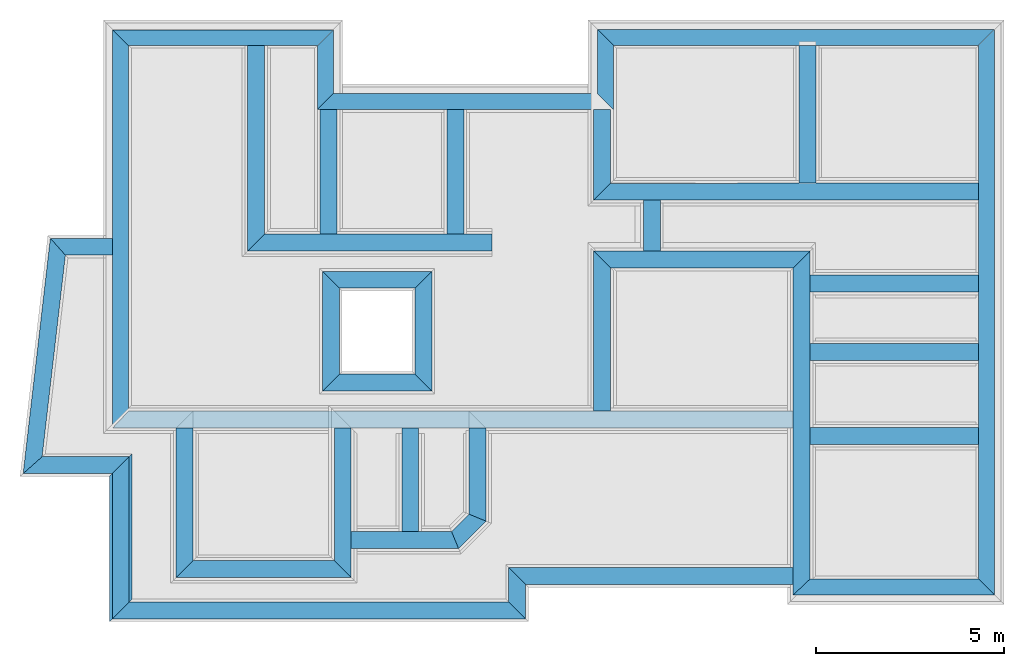
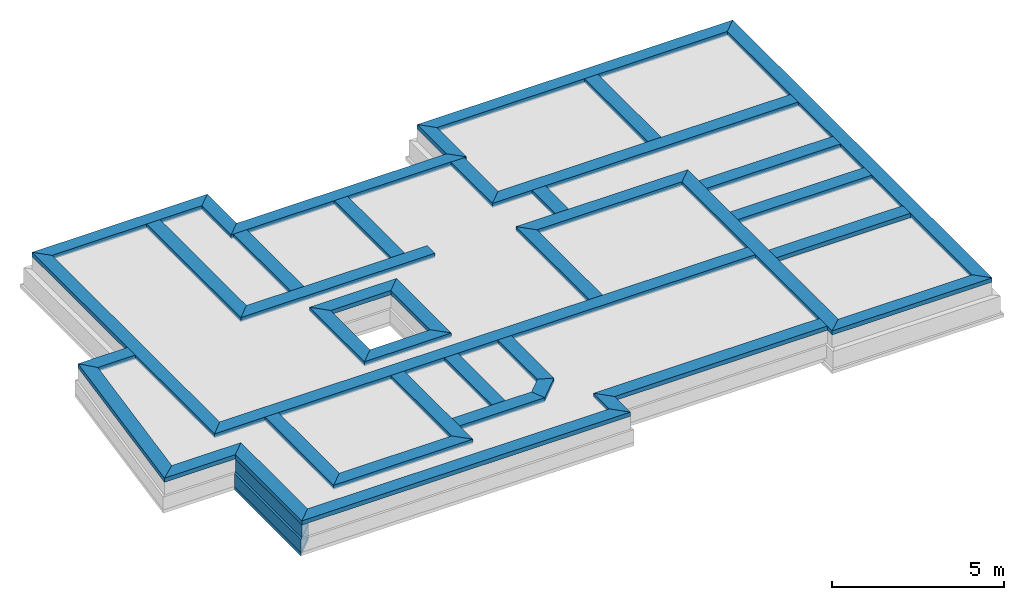
# One storey, part 1 of 6: 41 beams, 3 walls.
"""IFC4X3_ADD2 building model written with IfcOpenShell, lengths in metres."""

from ifc_helpers import new_model, entity, si_unit, converted_unit, frame, origin_with_axes, origin_2d_with_axis, place, context, subcontext, project, spatial, line, indexed_curve, outline, extrude, material, layer, layer_set, layer_usage, type_object, element, save


model = new_model("IFC4X3_ADD2")

# Units and contexts
model_context = context("Model", 3, precision=1e-05, world=origin_with_axes())
plan_context = context("Plan", 2, precision=1e-05, world=origin_2d_with_axis())
body_context = subcontext(model_context, "Body", "Model", "MODEL_VIEW")
ifc_project = project(units=[si_unit("VOLUMEUNIT", "CUBIC_METRE"), si_unit("LENGTHUNIT", "METRE"), converted_unit("PLANEANGLEUNIT", "degree", entity("IfcReal", 0.0174532925199433), si_unit("PLANEANGLEUNIT", "RADIAN"), dimensions=[0, 0, 0, 0, 0, 0, 0]), si_unit("AREAUNIT", "SQUARE_METRE")], contexts=[model_context, plan_context])

# Site, building, storey
site_placement = place(None, origin_with_axes())
site = spatial("IfcSite", under=ifc_project, at=site_placement)
building_placement = place(site_placement, origin_with_axes())
building = spatial("IfcBuilding", under=site, at=building_placement, Name="Building")
storey_placement = place(building_placement, frame((0.0, 0.0, -0.870000004768372), z_axis=(0.0, 0.0, 1.0), x_axis=(1.0, 0.0, 0.0)))
storey = spatial("IfcBuildingStorey", under=building, at=storey_placement, Name="Footing")

# Beams
ifc_material_1 = material(Name="brick2", Category="Materials")
ifc_layer_1 = layer(ifc_material_1, 0.00999999977648258)
ifc_material_2 = material(Name="Concrete")
ifc_layer_2 = layer(ifc_material_2, 0.405000001192093)
ifc_layer_3 = layer(ifc_material_1, 0.00999999977648258)
ifc_layer_set_1 = layer_set([ifc_layer_1, ifc_layer_2, ifc_layer_3], Name="concrete")
ifc_layer_usage_1 = layer_usage(ifc_layer_set_1, "AXIS2", "POSITIVE", 0.0)
beam_type_1 = type_object("IfcBeamType", Name="425mm wide beam", PredefinedType="BEAM", material=ifc_layer_set_1)
beam_1_placement = place(storey_placement, frame((18.1166839599609, 25.9979019165039, 1.16999995708466), z_axis=(0.0, 0.0, 1.0), x_axis=(3.13916473260163e-07, -0.999999999999951, 0.0)))
element("IfcBeam", 1, at=beam_1_placement, inside=storey, type_object=beam_type_1, material=ifc_layer_usage_1, Name="Beam", context=body_context, shape_type="SweptSolid", body=[
    extrude(outline(indexed_curve([(-0.425000000745059, 0.0), (-1.85773430742357e-08, 0.425000000745058), (1.70799196416283, 0.425000000745058), (1.28299198199511, 0.0)], segments=[line(1, 2, 3, 4, 1)])), origin_with_axes(), (0.0, 0.0, 1.0), 0.150000005960464),
])
ifc_layer_usage_2 = layer_usage(ifc_layer_set_1, "AXIS2", "POSITIVE", 0.0)
beam_2_placement = place(storey_placement, frame((10.6593037587962, 24.2899072712673, 1.16999995708466), z_axis=(0.0, 0.0, 1.0), x_axis=(0.999999999999936, 3.57627868652321e-07, 0.0)))
element("IfcBeam", 2, at=beam_2_placement, inside=storey, type_object=beam_type_1, material=ifc_layer_usage_2, Name="Beam", context=body_context, shape_type="SweptSolid", body=[
    extrude(outline(indexed_curve([(0.0, 0.0), (0.425000048504974, 0.425000000745058), (7.45738073603171, 0.425000000745058), (7.88238071161483, 0.0)], segments=[line(1, 2, 3, 4, 1)])), origin_with_axes(), (0.0, 0.0, 1.0), 0.150000005960464),
])
ifc_layer_usage_3 = layer_usage(ifc_layer_set_1, "AXIS2", "POSITIVE", 0.0)
beam_3_placement = place(storey_placement, frame((18.1166839599609, 25.9979019209745, 1.16999995708466), z_axis=(0.0, 0.0, 1.0), x_axis=(0.999999999999936, 3.57627868652321e-07, 0.0)))
element("IfcBeam", 3, at=beam_3_placement, inside=storey, type_object=beam_type_1, material=ifc_layer_usage_3, Name="Beam", context=body_context, shape_type="SweptSolid", body=[
    extrude(outline(indexed_curve([(0.425000000745059, 0.0), (2.51619385810791e-08, 0.425000000745058), (10.569989032995, 0.425000000745058), (10.1449890136726, 0.0)], segments=[line(1, 2, 3, 4, 1)])), origin_with_axes(), (0.0, 0.0, 1.0), 0.150000005960464),
])
ifc_layer_usage_4 = layer_usage(ifc_layer_set_1, "AXIS2", "POSITIVE", 0.0)
beam_4_placement = place(storey_placement, frame((28.2616729736329, 25.9979055491053, 1.16999995708466), z_axis=(0.0, 0.0, 1.0), x_axis=(3.13916473260163e-07, -0.999999999999951, 0.0)))
element("IfcBeam", 4, at=beam_4_placement, inside=storey, type_object=beam_type_1, material=ifc_layer_usage_4, Name="Beam", context=body_context, shape_type="SweptSolid", body=[
    extrude(outline(indexed_curve([(0.0, 0.0), (-0.425000019322402, 0.425000000745058), (14.6285606951178, 0.425000000745058), (14.2035607129501, 0.0)], segments=[line(1, 2, 3, 4, 1)])), origin_with_axes(), (0.0, 0.0, 1.0), 0.150000005960464),
])
ifc_layer_usage_5 = layer_usage(ifc_layer_set_1, "AXIS2", "POSITIVE", 0.0)
beam_5_placement = place(storey_placement, frame((23.3250172254903, 11.3693430699236, 1.16999995708466), z_axis=(0.0, 0.0, 1.0), x_axis=(0.999999999999936, 3.57627868652321e-07, 0.0)))
element("IfcBeam", 5, at=beam_5_placement, inside=storey, type_object=beam_type_1, material=ifc_layer_usage_5, Name="Beam", context=body_context, shape_type="SweptSolid", body=[
    extrude(outline(indexed_curve([(0.0, 0.0), (0.450000020620197, 0.425000000745058), (4.93666035886637, 0.425000000745058), (5.36166034103409, 0.0)], segments=[line(1, 2, 3, 4, 1)])), origin_with_axes(), (0.0, 0.0, 1.0), 0.150000005960464),
])
ifc_layer_usage_6 = layer_usage(ifc_layer_set_1, "AXIS2", "POSITIVE", 0.0)
beam_6_placement = place(storey_placement, frame((5.21403593350073, 25.9879012442737, 1.16999995708466), z_axis=(0.0, 0.0, 1.0), x_axis=(3.13916473260163e-07, -0.999999999999951, 0.0)))
element("IfcBeam", 6, at=beam_6_placement, inside=storey, type_object=beam_type_1, material=ifc_layer_usage_6, Name="Beam", context=body_context, shape_type="SweptSolid", body=[
    extrude(outline(indexed_curve([(-0.425000000745059, 0.0), (-1.85773430742357e-08, 0.425000000745058), (9.7218833779098, 0.425000000745058), (10.1718834035535, 0.0)], segments=[line(1, 2, 3, 4, 1)])), origin_with_axes(), (0.0, 0.0, 1.0), 0.150000005960464),
])
ifc_layer_usage_7 = layer_usage(ifc_layer_set_1, "AXIS2", "POSITIVE", 0.0)
beam_7_placement = place(storey_placement, frame((5.21403593350073, 25.9879012442737, 1.16999995708466), z_axis=(0.0, 0.0, 1.0), x_axis=(0.999999999999936, 3.57627868652321e-07, 0.0)))
element("IfcBeam", 7, at=beam_7_placement, inside=storey, type_object=beam_type_1, material=ifc_layer_usage_7, Name="Beam", context=body_context, shape_type="SweptSolid", body=[
    extrude(outline(indexed_curve([(0.425000000745059, 0.0), (1.96829825992962e-08, 0.425000000745058), (5.87026742918612, 0.425000000745058), (5.44526740885958, 0.0)], segments=[line(1, 2, 3, 4, 1)])), origin_with_axes(), (0.0, 0.0, 1.0), 0.150000005960464),
])
ifc_layer_usage_8 = layer_usage(ifc_layer_set_1, "AXIS2", "POSITIVE", 0.0)
beam_8_placement = place(storey_placement, frame((10.65930334236, 25.9879031916531, 1.16999995708466), z_axis=(0.0, 0.0, 1.0), x_axis=(3.13916473260163e-07, -0.999999999999951, 0.0)))
element("IfcBeam", 8, at=beam_8_placement, inside=storey, type_object=beam_type_1, material=ifc_layer_usage_8, Name="Beam", context=body_context, shape_type="SweptSolid", body=[
    extrude(outline(indexed_curve([(0.0, 0.0), (-0.425000019322402, 0.425000000745058), (1.2729959010635, 0.425000000745058), (1.6979959203859, 0.0)], segments=[line(1, 2, 3, 4, 1)])), origin_with_axes(), (0.0, 0.0, 1.0), 0.150000005960464),
])
ifc_layer_4 = layer(ifc_material_1, 0.00999999977648258)
ifc_material_3 = material(Name="Stone", Category="Structure")
ifc_layer_5 = layer(ifc_material_3, 0.430000007152557)
ifc_layer_6 = layer(ifc_material_1, 0.00999999977648258)
ifc_layer_set_2 = layer_set([ifc_layer_4, ifc_layer_5, ifc_layer_6], Name="concrete")
ifc_layer_usage_9 = layer_usage(ifc_layer_set_2, "AXIS2", "POSITIVE", 0.0)
beam_type_2 = type_object("IfcBeamType", Name="450mm wide beam", PredefinedType="BEAM", material=ifc_layer_set_2)
beam_9_placement = place(storey_placement, frame((8.80813704222451, 25.9978993535042, 1.16999995708466), z_axis=(0.0, 0.0, 1.0), x_axis=(1.94707183709394e-07, -0.999999999999981, 0.0)))
element("IfcBeam", 9, at=beam_9_placement, inside=storey, type_object=beam_type_2, material=ifc_layer_usage_9, Name="Beam", context=body_context, shape_type="SweptSolid", body=[
    extrude(outline(indexed_curve([(0.0, 0.0), (0.0, 0.450000006705522), (5.02351283316316, 0.450000006705522), (5.47351248493011, 0.0)], segments=[line(1, 2, 3, 4, 1)])), origin_with_axes(), (0.0, 0.0, 1.0), 0.150000005960464),
])
ifc_layer_usage_10 = layer_usage(ifc_layer_set_2, "AXIS2", "POSITIVE", 0.0)
beam_10_placement = place(storey_placement, frame((14.110216841721, 24.2899085054099, 1.16999995708466), z_axis=(0.0, 0.0, 1.0), x_axis=(3.13916473260163e-07, -0.999999999999951, 0.0)))
element("IfcBeam", 10, at=beam_10_placement, inside=storey, type_object=beam_type_2, material=ifc_layer_usage_10, Name="Beam", context=body_context, shape_type="SweptSolid", body=[
    extrude(outline(indexed_curve([(0.0, 0.0), (-1.96701282195799e-08, 0.450000006705522), (3.31552518321818, 0.450000006705522), (3.31552477503988, 0.0)], segments=[line(1, 2, 3, 4, 1)])), origin_with_axes(), (0.0, 0.0, 1.0), 0.150000005960464),
])
ifc_layer_usage_11 = layer_usage(ifc_layer_set_2, "AXIS2", "POSITIVE", 0.0)
beam_11_placement = place(storey_placement, frame((23.4816800811879, 25.9979038396466, 1.16999995708466), z_axis=(0.0, 0.0, 1.0), x_axis=(3.13916473260163e-07, -0.999999999999951, 0.0)))
element("IfcBeam", 11, at=beam_11_placement, inside=storey, type_object=beam_type_2, material=ifc_layer_usage_11, Name="Beam", context=body_context, shape_type="SweptSolid", body=[
    extrude(outline(indexed_curve([(0.0, 0.0), (-1.96701282195799e-08, 0.450000006705522), (3.67000913781649, 0.450000006705522), (3.67000915865293, 0.0)], segments=[line(1, 2, 3, 4, 1)])), origin_with_axes(), (0.0, 0.0, 1.0), 0.150000005960464),
])
ifc_layer_usage_12 = layer_usage(ifc_layer_set_2, "AXIS2", "POSITIVE", 0.0)
beam_12_placement = place(storey_placement, frame((18.0166816711424, 24.2899099024706, 1.16999995708466), z_axis=(0.0, 0.0, 1.0), x_axis=(3.13916473260163e-07, -0.999999999999951, 0.0)))
element("IfcBeam", 12, at=beam_12_placement, inside=storey, type_object=beam_type_2, material=ifc_layer_usage_12, Name="Beam", context=body_context, shape_type="SweptSolid", body=[
    extrude(outline(indexed_curve([(0.0, 0.0), (-1.96701282195798e-08, 0.450000006705522), (1.96201718267913, 0.450000006705522), (2.41201721245263, 0.0)], segments=[line(1, 2, 3, 4, 1)])), origin_with_axes(), (0.0, 0.0, 1.0), 0.150000005960464),
])
ifc_layer_usage_13 = layer_usage(ifc_layer_set_2, "AXIS2", "POSITIVE", 0.0)
beam_13_placement = place(storey_placement, frame((18.0166824547765, 21.8778927056883, 1.16999995708466), z_axis=(0.0, 0.0, 1.0), x_axis=(0.999999999999936, 3.57627868652321e-07, 0.0)))
element("IfcBeam", 13, at=beam_13_placement, inside=storey, type_object=beam_type_2, material=ifc_layer_usage_13, Name="Beam", context=body_context, shape_type="SweptSolid", body=[
    extrude(outline(indexed_curve([(0.0, 0.0), (0.450000021438708, 0.450000006705522), (10.2449918318659, 0.450000006705522), (10.2449918121957, 0.0)], segments=[line(1, 2, 3, 4, 1)])), origin_with_axes(), (0.0, 0.0, 1.0), 0.150000005960464),
])
ifc_layer_usage_14 = layer_usage(ifc_layer_set_2, "AXIS2", "POSITIVE", 0.0)
beam_14_placement = place(storey_placement, frame((23.3250144526521, 20.0728968029, 1.16999995708466), z_axis=(0.0, 0.0, 1.0), x_axis=(3.13916473260163e-07, -0.999999999999951, 0.0)))
element("IfcBeam", 14, at=beam_14_placement, inside=storey, type_object=beam_type_2, material=ifc_layer_usage_14, Name="Beam", context=body_context, shape_type="SweptSolid", body=[
    extrude(outline(indexed_curve([(0.0, 0.0), (-0.450000027679134, 0.450000006705522), (8.2785537125617, 0.450000006705522), (8.70355373297689, 0.0)], segments=[line(1, 2, 3, 4, 1)])), origin_with_axes(), (0.0, 0.0, 1.0), 0.150000005960464),
])
ifc_layer_usage_15 = layer_usage(ifc_layer_set_2, "AXIS2", "POSITIVE", 0.0)
beam_15_placement = place(storey_placement, frame((18.0166815696099, 20.072894889116, 1.16999995708466), z_axis=(0.0, 0.0, 1.0), x_axis=(0.999999999999936, 3.57627868652321e-07, 0.0)))
element("IfcBeam", 15, at=beam_15_placement, inside=storey, type_object=beam_type_2, material=ifc_layer_usage_15, Name="Beam", context=body_context, shape_type="SweptSolid", body=[
    extrude(outline(indexed_curve([(0.450000006705523, 0.0), (1.96701282484391e-08, 0.450000006705522), (5.75833290805005, 0.450000006705522), (5.30833288304257, 0.0)], segments=[line(1, 2, 3, 4, 1)])), origin_with_axes(), (0.0, 0.0, 1.0), 0.150000005960464),
])
ifc_layer_usage_16 = layer_usage(ifc_layer_set_2, "AXIS2", "POSITIVE", 0.0)
beam_16_placement = place(storey_placement, frame((23.3250146565525, 19.4295903581414, 1.16999995708466), z_axis=(0.0, 0.0, 1.0), x_axis=(0.999999999999936, 3.57627868652321e-07, 0.0)))
element("IfcBeam", 16, at=beam_16_placement, inside=storey, type_object=beam_type_2, material=ifc_layer_usage_16, Name="Beam", context=body_context, shape_type="SweptSolid", body=[
    extrude(outline(indexed_curve([(0.450000006705522, 0.0), (0.450000025007475, 0.450000006705522), (4.93666039865257, 0.450000006705522), (4.93666037898244, 0.0)], segments=[line(1, 2, 3, 4, 1)])), origin_with_axes(), (0.0, 0.0, 1.0), 0.150000005960464),
])
ifc_layer_usage_17 = layer_usage(ifc_layer_set_2, "AXIS2", "POSITIVE", 0.0)
beam_17_placement = place(storey_placement, frame((23.3250141143799, 17.6093635559082, 1.16999995708466), z_axis=(0.0, 0.0, 1.0), x_axis=(0.999999999999936, 3.57627868652321e-07, 0.0)))
element("IfcBeam", 17, at=beam_17_placement, inside=storey, type_object=beam_type_2, material=ifc_layer_usage_17, Name="Beam", context=body_context, shape_type="SweptSolid", body=[
    extrude(outline(indexed_curve([(0.450000006705522, 0.0), (0.450000025007475, 0.450000006705522), (4.93666039865257, 0.450000006705522), (4.93666037898244, 0.0)], segments=[line(1, 2, 3, 4, 1)])), origin_with_axes(), (0.0, 0.0, 1.0), 0.150000005960464),
])
ifc_layer_usage_18 = layer_usage(ifc_layer_set_2, "AXIS2", "POSITIVE", 0.0)
beam_18_placement = place(storey_placement, frame((23.3250141143799, 15.3793487548828, 1.16999995708466), z_axis=(0.0, 0.0, 1.0), x_axis=(0.999999999999936, 3.57627868652321e-07, 0.0)))
element("IfcBeam", 18, at=beam_18_placement, inside=storey, type_object=beam_type_2, material=ifc_layer_usage_18, Name="Beam", context=body_context, shape_type="SweptSolid", body=[
    extrude(outline(indexed_curve([(0.450000006705522, 0.0), (0.450000025007475, 0.450000006705522), (4.93666039865257, 0.450000006705522), (4.93666037898244, 0.0)], segments=[line(1, 2, 3, 4, 1)])), origin_with_axes(), (0.0, 0.0, 1.0), 0.150000005960464),
])
ifc_layer_usage_19 = layer_usage(ifc_layer_set_2, "AXIS2", "POSITIVE", 0.0)
beam_19_placement = place(storey_placement, frame((19.3416843414307, 21.877893447876, 1.16999995708466), z_axis=(0.0, 0.0, 1.0), x_axis=(3.13916473260163e-07, -0.999999999999951, 0.0)))
element("IfcBeam", 19, at=beam_19_placement, inside=storey, type_object=beam_type_2, material=ifc_layer_usage_19, Name="Beam", context=body_context, shape_type="SweptSolid", body=[
    extrude(outline(indexed_curve([(0.0, 0.0), (-2.08324514101375e-08, 0.450000006705522), (1.35499778938149, 0.450000006705522), (1.35499781047584, 0.0)], segments=[line(1, 2, 3, 4, 1)])), origin_with_axes(), (0.0, 0.0, 1.0), 0.150000005960464),
])
ifc_layer_usage_20 = layer_usage(ifc_layer_set_2, "AXIS2", "POSITIVE", 0.0)
beam_20_placement = place(storey_placement, frame((18.0166815696099, 20.0728948876918, 1.16999995708466), z_axis=(0.0, 0.0, 1.0), x_axis=(3.13916473260163e-07, -0.999999999999951, 0.0)))
element("IfcBeam", 20, at=beam_20_placement, inside=storey, type_object=beam_type_2, material=ifc_layer_usage_20, Name="Beam", context=body_context, shape_type="SweptSolid", body=[
    extrude(outline(indexed_curve([(-0.450000006705523, 0.0), (-2.09736109838054e-08, 0.450000006705522), (3.80687243920009, 0.450000006705522), (3.80687245990194, 0.0)], segments=[line(1, 2, 3, 4, 1)])), origin_with_axes(), (0.0, 0.0, 1.0), 0.150000005960464),
])
ifc_layer_usage_21 = layer_usage(ifc_layer_set_2, "AXIS2", "POSITIVE", 0.0)
beam_21_placement = place(storey_placement, frame((5.21403910016029, 15.8160178407207, 1.16999995708466), z_axis=(0.0, 0.0, 1.0), x_axis=(0.999999999999936, 3.57627868652321e-07, 0.0)))
element("IfcBeam", 21, at=beam_21_placement, inside=storey, type_object=beam_type_2, material=ifc_layer_usage_21, Name="Beam", context=body_context, shape_type="SweptSolid", body=[
    extrude(outline(indexed_curve([(0.0, 0.0), (0.425000021585864, 0.450000006705522), (18.1109767200399, 0.450000006705522), (18.1109767017379, 0.0)], segments=[line(1, 2, 3, 4, 1)])), origin_with_axes(), (0.0, 0.0, 1.0), 0.150000005960464),
])
ifc_layer_usage_22 = layer_usage(ifc_layer_set_2, "AXIS2", "POSITIVE", 0.0)
beam_22_placement = place(storey_placement, frame((14.6966757752904, 15.8160212390453, 1.16999995708466), z_axis=(0.0, 0.0, 1.0), x_axis=(3.13916473260163e-07, -0.999999999999951, 0.0)))
element("IfcBeam", 22, at=beam_22_placement, inside=storey, type_object=beam_type_2, material=ifc_layer_usage_22, Name="Beam", context=body_context, shape_type="SweptSolid", body=[
    extrude(outline(indexed_curve([(0.0, 0.0), (-2.0103359660383e-08, 0.450000006705522), (2.48110810332906, 0.450000006705522), (2.29471198139448, 0.0)], segments=[line(1, 2, 3, 4, 1)])), origin_with_axes(), (0.0, 0.0, 1.0), 0.150000005960464),
])
ifc_layer_usage_23 = layer_usage(ifc_layer_set_2, "AXIS2", "POSITIVE", 0.0)
beam_23_placement = place(storey_placement, frame((14.6966764956383, 13.5213092576509, 1.16999995708466), z_axis=(0.0, 0.0, 1.0), x_axis=(-0.707106602372588, -0.707106960000462, 0.0)))
element("IfcBeam", 23, at=beam_23_placement, inside=storey, type_object=beam_type_2, material=ifc_layer_usage_23, Name="Beam", context=body_context, shape_type="SweptSolid", body=[
    extrude(outline(indexed_curve([(0.0, 0.0), (-0.186396121934575, 0.450000006705522), (0.842713639025092, 0.450000006705522), (0.65631756226547, 0.0)], segments=[line(1, 2, 3, 4, 1)])), origin_with_axes(), (0.0, 0.0, 1.0), 0.150000005960464),
])
ifc_layer_usage_24 = layer_usage(ifc_layer_set_2, "AXIS2", "POSITIVE", 0.0)
beam_24_placement = place(storey_placement, frame((11.1129999696974, 12.6072214047061, 1.16999995708466), z_axis=(0.0, 0.0, 1.0), x_axis=(0.999999999999936, 3.57627868652321e-07, 0.0)))
element("IfcBeam", 24, at=beam_24_placement, inside=storey, type_object=beam_type_2, material=ifc_layer_usage_24, Name="Beam", context=body_context, shape_type="SweptSolid", body=[
    extrude(outline(indexed_curve([(0.450000006705523, 0.0), (0.450000026375651, 0.450000006705522), (3.11959019100417, 0.450000006705522), (3.30598626923792, 0.0)], segments=[line(1, 2, 3, 4, 1)])), origin_with_axes(), (0.0, 0.0, 1.0), 0.150000005960464),
])
ifc_layer_usage_25 = layer_usage(ifc_layer_set_2, "AXIS2", "POSITIVE", 0.0)
beam_25_placement = place(storey_placement, frame((12.9089555740357, 15.8160205991703, 1.16999995708466), z_axis=(0.0, 0.0, 1.0), x_axis=(3.13916473260163e-07, -0.999999999999951, 0.0)))
element("IfcBeam", 25, at=beam_25_placement, inside=storey, type_object=beam_type_2, material=ifc_layer_usage_25, Name="Beam", context=body_context, shape_type="SweptSolid", body=[
    extrude(outline(indexed_curve([(0.0, 0.0), (-2.00521794216641e-08, 0.450000006705522), (2.75879851585852, 0.450000006705522), (2.75879853752143, 0.0)], segments=[line(1, 2, 3, 4, 1)])), origin_with_axes(), (0.0, 0.0, 1.0), 0.150000005960464),
])
ifc_layer_usage_26 = layer_usage(ifc_layer_set_2, "AXIS2", "POSITIVE", 0.0)
beam_26_placement = place(storey_placement, frame((11.1129989624023, 15.8160209655762, 1.16999995708466), z_axis=(0.0, 0.0, 1.0), x_axis=(3.13916473260163e-07, -0.999999999999951, 0.0)))
element("IfcBeam", 26, at=beam_26_placement, inside=storey, type_object=beam_type_2, material=ifc_layer_usage_26, Name="Beam", context=body_context, shape_type="SweptSolid", body=[
    extrude(outline(indexed_curve([(0.0, 0.0), (0.0, 0.450000006705522), (3.9799980040806, 0.450000006705522), (3.52999801830902, 0.0)], segments=[line(1, 2, 3, 4, 1)])), origin_with_axes(), (0.0, 0.0, 1.0), 0.150000005960464),
])
ifc_layer_usage_27 = layer_usage(ifc_layer_set_2, "AXIS2", "POSITIVE", 0.0)
beam_27_placement = place(storey_placement, frame((6.9035966969277, 11.8360214233398, 1.16999995708466), z_axis=(0.0, 0.0, 1.0), x_axis=(0.999999999999936, 3.57627868652321e-07, 0.0)))
element("IfcBeam", 27, at=beam_27_placement, inside=storey, type_object=beam_type_2, material=ifc_layer_usage_27, Name="Beam", context=body_context, shape_type="SweptSolid", body=[
    extrude(outline(indexed_curve([(0.0, 0.0), (0.450000026375651, 0.450000006705522), (4.20940353453194, 0.450000006705522), (4.65940352156734, 0.0)], segments=[line(1, 2, 3, 4, 1)])), origin_with_axes(), (0.0, 0.0, 1.0), 0.150000005960464),
])
ifc_layer_usage_28 = layer_usage(ifc_layer_set_2, "AXIS2", "POSITIVE", 0.0)
beam_28_placement = place(storey_placement, frame((6.90359544754028, 15.8160209655762, 1.16999995708466), z_axis=(0.0, 0.0, 1.0), x_axis=(3.13916473260163e-07, -0.999999999999951, 0.0)))
element("IfcBeam", 28, at=beam_28_placement, inside=storey, type_object=beam_type_2, material=ifc_layer_usage_28, Name="Beam", context=body_context, shape_type="SweptSolid", body=[
    extrude(outline(indexed_curve([(0.0, 0.0), (0.0, 0.450000006705522), (3.52999951459715, 0.450000006705522), (3.97999954223662, 0.0)], segments=[line(1, 2, 3, 4, 1)])), origin_with_axes(), (0.0, 0.0, 1.0), 0.150000005960464),
])
ifc_layer_usage_29 = layer_usage(ifc_layer_set_2, "AXIS2", "POSITIVE", 0.0)
beam_29_placement = place(storey_placement, frame((10.734302408552, 24.2899072980889, 1.16999995708466), z_axis=(0.0, 0.0, 1.0), x_axis=(3.13916473260163e-07, -0.999999999999951, 0.0)))
element("IfcBeam", 29, at=beam_29_placement, inside=storey, type_object=beam_type_2, material=ifc_layer_usage_29, Name="Beam", context=body_context, shape_type="SweptSolid", body=[
    extrude(outline(indexed_curve([(0.0, 0.0), (-1.96701281929279e-08, 0.450000006705522), (3.31552197348559, 0.450000006705522), (3.31552156530729, 0.0)], segments=[line(1, 2, 3, 4, 1)])), origin_with_axes(), (0.0, 0.0, 1.0), 0.150000005960464),
])
ifc_layer_usage_30 = layer_usage(ifc_layer_set_2, "AXIS2", "POSITIVE", 0.0)
beam_30_placement = place(storey_placement, frame((8.80813810795671, 20.5243868685742, 1.16999995708466), z_axis=(0.0, 0.0, 1.0), x_axis=(0.999999999999822, -5.960464477538e-07, 0.0)))
element("IfcBeam", 30, at=beam_30_placement, inside=storey, type_object=beam_type_2, material=ifc_layer_usage_30, Name="Beam", context=body_context, shape_type="SweptSolid", body=[
    extrude(outline(indexed_curve([(0.0, 0.0), (0.449999650866523, 0.450000006705522), (6.50208187103272, 0.450000006705522), (6.50208187103272, 0.0)], segments=[line(1, 2, 3, 4, 1)])), origin_with_axes(), (0.0, 0.0, 1.0), 0.150000005960464),
])
ifc_layer_usage_31 = layer_usage(ifc_layer_set_2, "AXIS2", "POSITIVE", 0.0)
beam_31_placement = place(storey_placement, frame((15.7540448127226, 11.6493429189982, 1.16999995708466), z_axis=(0.0, 0.0, 1.0), x_axis=(0.999999999999936, 3.57627868652321e-07, 0.0)))
element("IfcBeam", 31, at=beam_31_placement, inside=storey, type_object=beam_type_2, material=ifc_layer_usage_31, Name="Beam", context=body_context, shape_type="SweptSolid", body=[
    extrude(outline(indexed_curve([(0.450000006705523, 0.0), (1.96701282195799e-08, 0.450000006705522), (7.57097232813434, 0.450000006705522), (7.57097230983239, 0.0)], segments=[line(1, 2, 3, 4, 1)])), origin_with_axes(), (0.0, 0.0, 1.0), 0.150000005960464),
])
ifc_layer_usage_32 = layer_usage(ifc_layer_set_2, "AXIS2", "POSITIVE", 0.0)
beam_32_placement = place(storey_placement, frame((15.7540448127226, 11.6493429189982, 1.16999995708466), z_axis=(0.0, 0.0, 1.0), x_axis=(3.13916473260163e-07, -0.999999999999951, 0.0)))
element("IfcBeam", 32, at=beam_32_placement, inside=storey, type_object=beam_type_2, material=ifc_layer_usage_32, Name="Beam", context=body_context, shape_type="SweptSolid", body=[
    extrude(outline(indexed_curve([(-0.450000006705523, 0.0), (-2.04372883874935e-08, 0.450000006705522), (0.913205436559926, 0.450000006705522), (0.463205450491675, 0.0)], segments=[line(1, 2, 3, 4, 1)])), origin_with_axes(), (0.0, 0.0, 1.0), 0.150000005960464),
])
ifc_layer_usage_33 = layer_usage(ifc_layer_set_2, "AXIS2", "POSITIVE", 0.0)
beam_33_placement = place(storey_placement, frame((5.20271757983026, 10.7361336765302, 1.16999995708466), z_axis=(0.0, 0.0, 1.0), x_axis=(0.999999999999936, 3.57627868652321e-07, 0.0)))
element("IfcBeam", 33, at=beam_33_placement, inside=storey, type_object=beam_type_2, material=ifc_layer_usage_33, Name="Beam", context=body_context, shape_type="SweptSolid", body=[
    extrude(outline(indexed_curve([(0.0, 0.0), (0.45000002637565, 0.450000006705522), (10.5513275392333, 0.450000006705522), (11.0013275262687, 0.0)], segments=[line(1, 2, 3, 4, 1)])), origin_with_axes(), (0.0, 0.0, 1.0), 0.150000005960464),
])
ifc_layer_usage_34 = layer_usage(ifc_layer_set_2, "AXIS2", "POSITIVE", 0.0)
beam_34_placement = place(storey_placement, frame((5.20271636677999, 14.6003790231918, 1.16999995708466), z_axis=(0.0, 0.0, 1.0), x_axis=(3.13916473260163e-07, -0.999999999999951, 0.0)))
element("IfcBeam", 34, at=beam_34_placement, inside=storey, type_object=beam_type_2, material=ifc_layer_usage_34, Name="Beam", context=body_context, shape_type="SweptSolid", body=[
    extrude(outline(indexed_curve([(0.0, 0.0), (-0.450000028368439, 0.450000006705522), (3.41424531978198, 0.450000006705522), (3.86424534666183, 0.0)], segments=[line(1, 2, 3, 4, 1)])), origin_with_axes(), (0.0, 0.0, 1.0), 0.150000005960464),
])
ifc_layer_usage_35 = layer_usage(ifc_layer_set_2, "AXIS2", "POSITIVE", 0.0)
beam_35_placement = place(storey_placement, frame((3.28399853057781, 14.6003783249363, 1.16999995708466), z_axis=(0.0, 0.0, 1.0), x_axis=(0.999999999999936, 3.57627868652321e-07, 0.0)))
element("IfcBeam", 35, at=beam_35_placement, inside=storey, type_object=beam_type_2, material=ifc_layer_usage_35, Name="Beam", context=body_context, shape_type="SweptSolid", body=[
    extrude(outline(indexed_curve([(-0.452991198784577, 0.0), (0.0519713396144295, 0.450000006705522), (2.36871786257795, 0.450000006705522), (1.9187178362023, 0.0)], segments=[line(1, 2, 3, 4, 1)])), origin_with_axes(), (0.0, 0.0, 1.0), 0.150000005960464),
])
ifc_layer_usage_36 = layer_usage(ifc_layer_set_2, "AXIS2", "POSITIVE", 0.0)
beam_36_placement = place(storey_placement, frame((3.95536313564383, 20.4134866076835, 1.16999995708466), z_axis=(0.0, 0.0, 1.0), x_axis=(0.999999999999936, 3.57627868652321e-07, 0.0)))
element("IfcBeam", 36, at=beam_36_placement, inside=storey, type_object=beam_type_2, material=ifc_layer_usage_36, Name="Beam", context=body_context, shape_type="SweptSolid", body=[
    extrude(outline(indexed_curve([(0.0, 0.0), (-0.401019859170148, 0.450000006705522), (1.25867455409636, 0.450000006705522), (1.25867453325556, 0.0)], segments=[line(1, 2, 3, 4, 1)])), origin_with_axes(), (0.0, 0.0, 1.0), 0.150000005960464),
])
ifc_layer_usage_37 = layer_usage(ifc_layer_set_2, "AXIS2", "POSITIVE", 0.0)
beam_37_placement = place(storey_placement, frame((10.7956827422968, 19.5343851122715, 1.16999995708466), z_axis=(0.0, 0.0, 1.0), x_axis=(3.13916473260163e-07, -0.999999999999951, 0.0)))
element("IfcBeam", 37, at=beam_37_placement, inside=storey, type_object=beam_type_2, material=ifc_layer_usage_37, Name="Beam", context=body_context, shape_type="SweptSolid", body=[
    extrude(outline(indexed_curve([(-0.450000006705523, 0.0), (-1.96701281929279e-08, 0.450000006705522), (2.28836896166128, 0.450000006705522), (2.73836898803694, 0.0)], segments=[line(1, 2, 3, 4, 1)])), origin_with_axes(), (0.0, 0.0, 1.0), 0.150000005960464),
])
ifc_layer_usage_38 = layer_usage(ifc_layer_set_2, "AXIS2", "POSITIVE", 0.0)
beam_38_placement = place(storey_placement, frame((13.2589586517204, 19.5343859932076, 1.16999995708466), z_axis=(0.0, 0.0, 1.0), x_axis=(3.13916473260163e-07, -0.999999999999951, 0.0)))
element("IfcBeam", 38, at=beam_38_placement, inside=storey, type_object=beam_type_2, material=ifc_layer_usage_38, Name="Beam", context=body_context, shape_type="SweptSolid", body=[
    extrude(outline(indexed_curve([(0.0, 0.0), (-0.450000026375651, 0.450000006705522), (2.73836896836681, 0.450000006705522), (2.28836898133141, 0.0)], segments=[line(1, 2, 3, 4, 1)])), origin_with_axes(), (0.0, 0.0, 1.0), 0.150000005960464),
])
ifc_layer_usage_39 = layer_usage(ifc_layer_set_2, "AXIS2", "POSITIVE", 0.0)
beam_39_placement = place(storey_placement, frame((10.7956827422968, 19.5343851122715, 1.16999989748001), z_axis=(0.0, 0.0, 1.0), x_axis=(0.999999999999936, 3.57627868652321e-07, 0.0)))
element("IfcBeam", 39, at=beam_39_placement, inside=storey, type_object=beam_type_2, material=ifc_layer_usage_39, Name="Beam", context=body_context, shape_type="SweptSolid", body=[
    extrude(outline(indexed_curve([(0.450000006705523, 0.0), (1.96701282195799e-08, 0.450000006705522), (2.91327593579936, 0.450000006705522), (2.46327590942371, 0.0)], segments=[line(1, 2, 3, 4, 1)])), origin_with_axes(), (0.0, 0.0, 1.0), 0.150000005960464),
])
ifc_layer_usage_40 = layer_usage(ifc_layer_set_2, "AXIS2", "POSITIVE", 0.0)
beam_40_placement = place(storey_placement, frame((10.795683601916, 16.7960161242347, 1.16999989748001), z_axis=(0.0, 0.0, 1.0), x_axis=(0.999999999999936, 3.57627868652321e-07, 0.0)))
element("IfcBeam", 40, at=beam_40_placement, inside=storey, type_object=beam_type_2, material=ifc_layer_usage_40, Name="Beam", context=body_context, shape_type="SweptSolid", body=[
    extrude(outline(indexed_curve([(0.0, 0.0), (0.450000026375651, 0.450000006705522), (2.46327592909384, 0.450000006705522), (2.91327591612923, 0.0)], segments=[line(1, 2, 3, 4, 1)])), origin_with_axes(), (0.0, 0.0, 1.0), 0.150000005960464),
])
ifc_layer_usage_41 = layer_usage(ifc_layer_set_2, "AXIS2", "POSITIVE", 0.0)
beam_41_placement = place(storey_placement, frame((3.28399853098188, 14.600378328435, 1.16999995708466), z_axis=(0.0, 0.0, 1.0), x_axis=(0.114728892793783, 0.99339683971629, 0.0)))
element("IfcBeam", 41, at=beam_41_placement, inside=storey, type_object=beam_type_2, material=ifc_layer_usage_41, Name="Beam", context=body_context, shape_type="SweptSolid", body=[
    extrude(outline(indexed_curve([(0.452991199106924, 0.0), (-0.0519713424240595, 0.450000006705522), (6.25276817398, 0.450000006705522), (5.85174831480985, 0.0)], segments=[line(1, 2, 3, 4, 1)])), origin_with_axes(), (0.0, 0.0, 1.0), 0.150000005960464),
])

# Walls
ifc_layer_7 = layer(ifc_material_3, 0.449999988079071)
ifc_layer_set_3 = layer_set([ifc_layer_7])
ifc_layer_usage_42 = layer_usage(ifc_layer_set_3, "AXIS2", "POSITIVE", 0.0)
wall_type_1 = type_object("IfcWallType", Name="RRB Basement", PredefinedType="SHEAR", material=ifc_layer_set_3)
wall_1_placement = place(storey_placement, frame((5.652716636662, 10.7361380519159, 0.719999998807908), z_axis=(0.0, 0.0, 1.0), x_axis=(6.71544341912371e-07, 0.999999999999775, 0.0)))
element("IfcWall", 42, at=wall_1_placement, inside=storey, type_object=wall_type_1, material=ifc_layer_usage_42, Name="Wall", context=body_context, shape_type="SweptSolid", body=[
    extrude(outline(indexed_curve([(0.449999988079072, 0.0), (-3.11936364927887e-08, 0.449999988079071), (3.86423789734284, 0.449999988079071), (4.31423788649869, 0.0)], segments=[line(1, 2, 3, 4, 1)])), origin_with_axes(), (0.0, 0.0, 1.0), 0.449999988079071),
])
ifc_material_4 = material(Name="Wall")
ifc_layer_8 = layer(ifc_material_4, 0.600000023841858, Name="concrete")
ifc_layer_set_4 = layer_set([ifc_layer_8], Name="concrete")
ifc_layer_usage_43 = layer_usage(ifc_layer_set_4, "AXIS2", "POSITIVE", 0.0)
wall_type_2 = type_object("IfcWallType", Name="RRB Foundation", PredefinedType="SHEAR", material=ifc_layer_set_4)
wall_2_placement = place(storey_placement, frame((5.1277161086956, 15.1253715398588, 0.269999980926514), z_axis=(0.0, 0.0, 1.0), x_axis=(-5.2054855359522e-07, -0.999999999999865, 0.0)))
element("IfcWall", 43, at=wall_2_placement, inside=storey, type_object=wall_type_2, material=ifc_layer_usage_43, Name="Wall", context=body_context, shape_type="SweptSolid", body=[
    extrude(outline(indexed_curve([(0.600000023841861, 0.0), (5.95834321742705e-08, 0.600000023841858), (3.86423388614875, 0.600000023841858), (4.46423399237835, 0.0)], segments=[line(1, 2, 3, 4, 1)])), origin_with_axes(), (0.0, 0.0, 1.0), 0.449999988079071),
])
ifc_layer_9 = layer(ifc_material_4, 0.600000023841858, Name="concrete")
ifc_layer_set_5 = layer_set([ifc_layer_9], Name="concrete")
ifc_layer_usage_44 = layer_usage(ifc_layer_set_5, "AXIS2", "POSITIVE", 0.0)
wall_type_3 = type_object("IfcWallType", Name="60CM PCC", PredefinedType="SHEAR", material=ifc_layer_set_5)
wall_3_placement = place(storey_placement, frame((5.12771610869562, 15.1253715864194, 0.149999976158143), z_axis=(0.0, 0.0, 1.0), x_axis=(-5.2054855359522e-07, -0.999999999999865, 0.0)))
element("IfcWall", 44, at=wall_3_placement, inside=storey, type_object=wall_type_3, material=ifc_layer_usage_44, Name="Wall", context=body_context, shape_type="SweptSolid", body=[
    extrude(outline(indexed_curve([(0.600000023841861, 0.0), (5.96269755653855e-08, 0.600000023841858), (3.86423364064859, 0.600000023841858), (4.46423374687819, 0.0)], segments=[line(1, 2, 3, 4, 1)])), origin_with_axes(), (0.0, 0.0, 1.0), 0.119999997317791),
])

save(model, "model.ifc")
